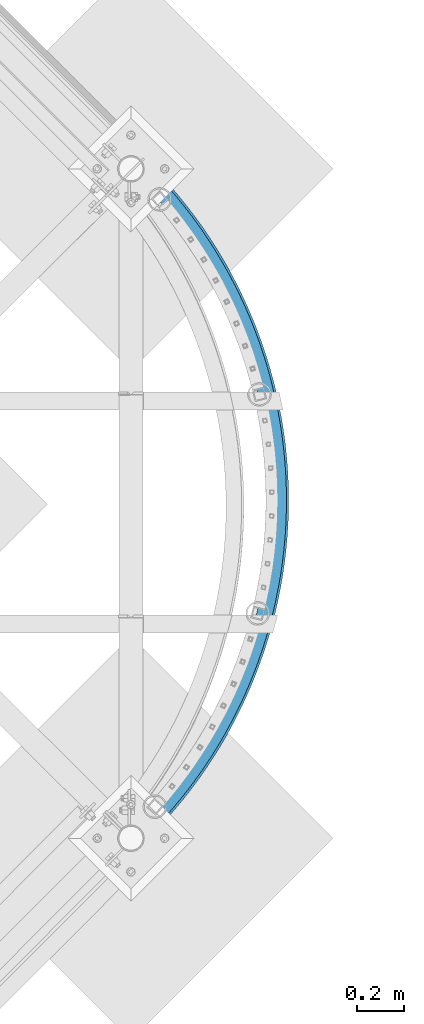
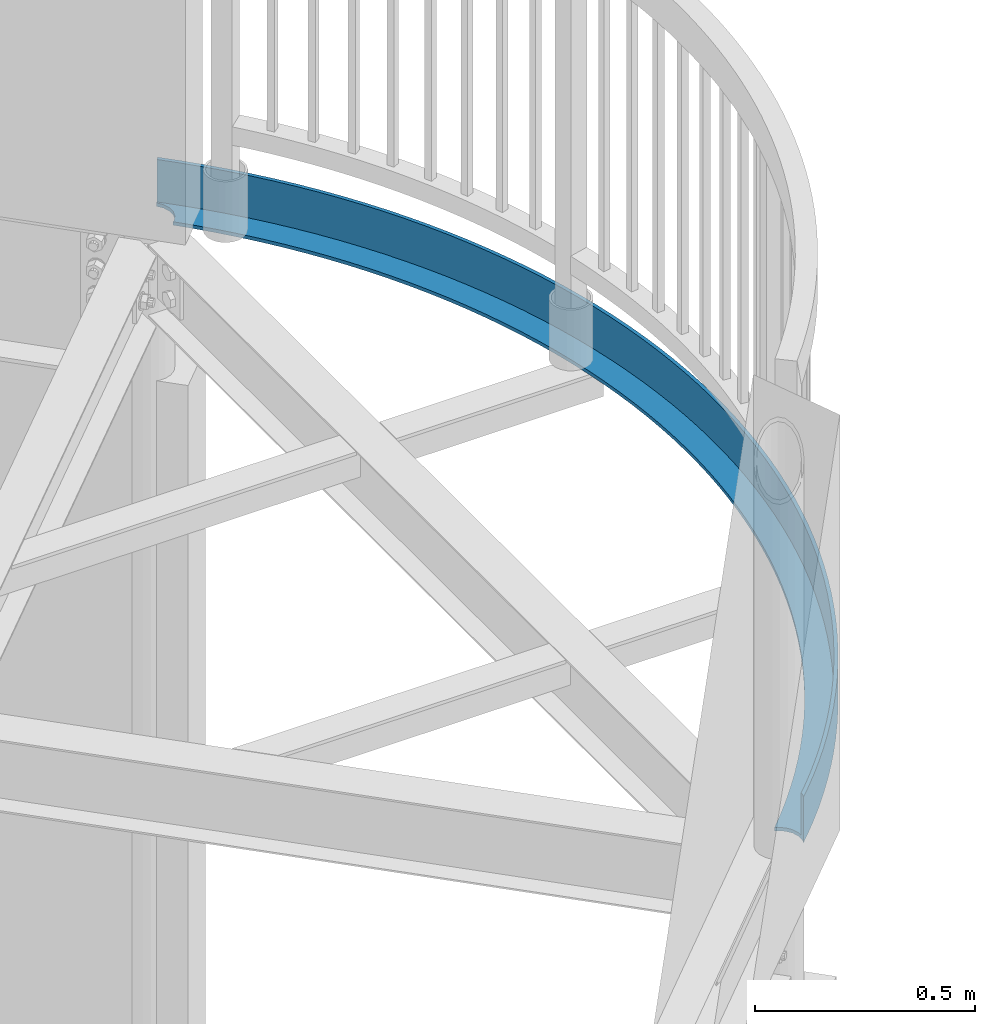
# One storey, part 372 of 975: 1 beam.
"""IFC2X3 building model written with IfcOpenShell, lengths in millimetres."""

from ifc_helpers import new_model, si_unit, frame, origin_with_axes, place, context, subcontext, project, spatial, faceted_brep, material, type_object, element, save


model = new_model("IFC2X3")

# Units and contexts
model_context = context("Model", 3, precision=1e-05, world=origin_with_axes())
body_context = subcontext(model_context, "Body", "Model", "MODEL_VIEW")
ifc_project = project(units=[si_unit("LENGTHUNIT", "METRE", prefix="MILLI"), si_unit("AREAUNIT", "SQUARE_METRE"), si_unit("VOLUMEUNIT", "CUBIC_METRE"), si_unit("MASSUNIT", "GRAM", prefix="KILO"), si_unit("TIMEUNIT", "SECOND"), si_unit("PLANEANGLEUNIT", "RADIAN"), si_unit("SOLIDANGLEUNIT", "STERADIAN"), si_unit("THERMODYNAMICTEMPERATUREUNIT", "DEGREE_CELSIUS"), si_unit("LUMINOUSINTENSITYUNIT", "LUMEN")], contexts=[model_context])

# Site, building, storey
site_placement = place(None, origin_with_axes())
site = spatial("IfcSite", under=ifc_project, at=site_placement, CompositionType="ELEMENT")
building_placement = place(site_placement, origin_with_axes())
building = spatial("IfcBuilding", under=site, at=building_placement, Name="Undefined", CompositionType="ELEMENT")
storey_placement = place(building_placement, origin_with_axes())
storey = spatial("IfcBuildingStorey", under=building, at=storey_placement, Name="Undefined", CompositionType="ELEMENT", Elevation=0.0)

# Beam
ifc_material = material(Name="STEEL/A36")
beam_type = type_object("IfcBeamType", Name="L5X3X3/8", PredefinedType="NOTDEFINED")
beam_placement = place(storey_placement, frame((35561.2099858616, 13119.3966204325, 4000.5), z_axis=(0.0, 0.0, 1.0), x_axis=(-0.00469841200188729, -0.999988962401416, 0.0)))
element("IfcBeam", 1, at=beam_placement, inside=storey, type_object=beam_type, material=ifc_material, Name="ANGLE", ObjectType="L5X3X3/8", context=body_context, shape_type="Brep", body=[
    faceted_brep([(2825.13390224894, 8.48867532257282, -53.9749999999999), (2825.13390224894, 8.48867532257282, -63.5), (2827.4700929227, 15.7953649505871, -63.5), (2827.4700929227, 15.7953649505871, -53.9750000000004), (2837.91188190403, 30.3101804705875, -63.5), (2837.91188190403, 30.3101804705875, -53.9750000000004), (2852.32793802244, 40.8879001067689, -63.5), (2852.32793802244, 40.8879001067689, -53.9749999999999), (2869.30711726249, 46.4931029618456, -63.5), (2869.30711726249, 46.4931029618456, -53.9749999999999), (2881.17687559119, 46.5488725923351, 63.5), (2881.17687559119, 46.5488725923351, -53.9749999999999), (2887.18737925926, 46.5771127266125, -63.5), (2887.18737925926, 46.5771127266125, 63.5), (2897.80763996452, 43.1814636329655, 63.5), (2897.80763996452, 43.1814636329655, -63.5), (2828.72669331991, 97.9177942949682, 63.5), (2828.72669331991, 97.9177942949682, -53.9749999999999), (2868.63149026365, 59.3560200991269, -53.9749999999999), (2868.63149026365, 59.3560200991269, 63.5), (2787.77896454822, 135.370254250112, 63.5), (2787.77896454822, 135.370254250112, -53.9749999999999), (2745.81913086308, 171.685204413458, 63.5), (2745.81913086308, 171.685204413458, -53.9749999999999), (2702.87878112772, 206.835305591929, 63.5), (2702.87878112772, 206.835305591929, -53.9749999999999), (2658.99024237294, 240.794095532416, 63.5), (2658.99024237294, 240.794095532416, -53.9749999999999), (2614.18655546014, 273.536008843497, 63.5), (2614.18655546014, 273.536008843497, -53.9749999999999), (2568.50145020696, 305.036396242016, 63.5), (2568.50145020696, 305.036396242016, -53.9749999999999), (2521.9693199943, 335.271543109913, 63.5), (2521.9693199943, 335.271543109913, -53.9749999999999), (2474.62519587376, 364.218687347442, 63.5), (2474.62519587376, 364.218687347442, -53.9749999999999), (2426.50472019493, 391.856036509293, 63.5), (2426.50472019493, 391.856036509293, -53.9749999999999), (2377.64411977268, 418.162784210719, 63.5), (2377.64411977268, 418.162784210719, -53.9749999999999), (2328.08017861421, 443.119125791352, 63.5), (2328.08017861421, 443.119125791352, -53.9749999999999), (2277.8502102268, 466.706273224831, 63.5), (2277.8502102268, 466.706273224831, -53.9749999999999), (2226.99202952682, 488.9064692631, 63.5), (2226.99202952682, 488.9064692631, -53.9749999999999), (2175.54392437137, 509.70300080473, 63.5), (2175.54392437137, 509.70300080473, -53.9749999999999), (2123.54462673375, 529.080211477107, 63.5), (2123.54462673375, 529.080211477107, -53.9749999999999), (2071.03328354467, 547.023513423112, 63.5), (2071.03328354467, 547.023513423112, -53.9749999999999), (2018.04942722104, 563.519398283424, 63.5), (2018.04942722104, 563.519398283424, -53.9749999999999), (1964.63294590458, 578.555447366016, 63.5), (1964.63294590458, 578.555447366016, -53.9749999999999), (1910.82405343254, 592.120340995476, 63.5), (1910.82405343254, 592.120340995476, -53.9749999999999), (1856.66325906335, 604.203867034805, 63.5), (1856.66325906335, 604.203867034805, -53.9749999999999), (1802.19133697975, 614.796928573509, 63.5), (1802.19133697975, 614.796928573509, -53.9749999999999), (1747.44929559255, 623.891550776047, 63.5), (1747.44929559255, 623.891550776047, -53.9749999999999), (1692.47834666806, 631.480886885627, 63.5), (1692.47834666806, 631.480886885627, -53.9749999999999), (1637.31987430233, 637.55922337863, 63.5), (1637.31987430233, 637.55922337863, -53.9749999999999), (1582.01540376579, 642.121984265985, 63.5), (1582.01540376579, 642.121984265985, -53.9749999999999), (1526.6065702415, 645.165734538132, 63.5), (1526.6065702415, 645.165734538132, -53.9749999999999), (1471.13508748072, 646.68818275103, 63.5), (1471.13508748072, 646.68818275103, -53.9749999999999), (1415.64271639927, 646.688182751226, 63.5), (1415.64271639927, 646.688182751226, -53.9749999999999), (1360.17123363849, 645.165734538714, 63.5), (1360.17123363849, 645.165734538714, -53.9749999999999), (1304.7624001142, 642.121984266945, 63.5), (1304.7624001142, 642.121984266945, -53.9749999999999), (1249.45792957766, 637.559223379991, 63.5), (1249.45792957766, 637.559223379991, -53.9749999999999), (1194.29945721193, 631.480886887373, 63.5), (1194.29945721193, 631.480886887373, -53.9749999999999), (1139.32850828744, 623.891550778178, 63.5), (1139.32850828744, 623.891550778178, -53.9749999999999), (1084.58646690025, 614.796928576012, 63.5), (1084.58646690025, 614.796928576012, -53.9749999999999), (1030.11454481665, 604.203867037693, 63.5), (1030.11454481665, 604.203867037693, -53.9749999999999), (975.953750447461, 592.120340998743, 63.5), (975.953750447461, 592.120340998743, -53.9749999999999), (922.144857975429, 578.555447369661, 63.5), (922.144857975429, 578.555447369661, -53.9749999999999), (868.728376658968, 563.519398287433, 63.5), (868.728376658968, 563.519398287433, -53.9749999999999), (815.744520335351, 547.023513427499, 63.5), (815.744520335351, 547.023513427499, -53.9749999999999), (763.233177146274, 529.080211481858, 63.5), (763.233177146274, 529.080211481858, -53.9749999999999), (711.233879508653, 509.703000809852, 63.5), (711.233879508653, 509.703000809852, -53.9749999999999), (659.785774353209, 488.906469268579, 63.5), (659.785774353209, 488.906469268579, -53.9749999999999), (608.927593653245, 466.706273230659, 63.5), (608.927593653245, 466.706273230659, -53.9749999999999), (558.697625265839, 443.119125797537, 63.5), (558.697625265839, 443.119125797537, -53.9749999999999), (509.133684107373, 418.162784217253, 63.5), (509.133684107373, 418.162784217253, -53.9749999999999), (460.273083685131, 391.856036516161, 63.5), (460.273083685131, 391.856036516161, -53.9749999999999), (412.152608006316, 364.218687354653, 63.5), (412.152608006316, 364.218687354653, -53.9749999999999), (364.80848388577, 335.271543117451, 63.5), (364.80848388577, 335.271543117451, -53.9749999999999), (318.276353673127, 305.036396249874, 63.5), (318.276353673127, 305.036396249874, -53.9749999999999), (272.591248419958, 273.536008851675, 63.5), (272.591248419958, 273.536008851675, -53.9749999999999), (227.787561507164, 240.794095540907, 63.5), (227.787561507164, 240.794095540907, -53.9749999999999), (183.899022752392, 206.83530560074, 63.5), (183.899022752392, 206.83530560074, -53.9749999999999), (140.958673017045, 171.685204422567, 63.5), (140.958673017045, 171.685204422567, -53.9749999999999), (98.998839331909, 135.370254259513, 63.5), (98.998839331909, 135.370254259513, -53.9749999999999), (58.0511105602363, 97.9177943046452, 63.5), (58.0511105602363, 97.9177943046452, -53.9749999999999), (18.1463136165039, 59.356020109095, 63.5), (18.1463136165039, 59.356020109095, -53.9749999999999), (-20.6855097411844, 19.7139623554103, 63.5), (-20.6855097411844, 19.7139623554103, -53.9749999999999), (2783.05621668102, 49.3404004933182, -53.9749999999999), (2783.05621668102, 49.3404004933182, -63.5), (2821.64547086838, 12.0498935786673, -63.5), (2821.64547086838, 12.0498935786673, -53.9749999999999), (2743.45841303368, 85.5581639664306, -53.9749999999999), (2743.45841303368, 85.5581639664306, -63.5), (2702.88187056892, 120.675917970548, -53.9749999999999), (2702.88187056892, 120.675917970548, -63.5), (2661.3571367589, 154.667224604666, -53.9749999999999), (2661.3571367589, 154.667224604666, -63.5), (2618.91547290813, 187.506493997658, -53.9749999999999), (2618.91547290813, 187.506493997658, -63.5), (2575.58883061882, 219.169003573203, -53.9749999999999), (2575.58883061882, 219.169003573203, -63.5), (2531.40982773663, 249.630916661888, -53.9749999999999), (2531.40982773663, 249.630916661888, -63.5), (2486.41172379472, 278.869300446233, -53.9749999999999), (2486.41172379472, 278.869300446233, -63.5), (2440.62839497485, 306.862143225379, -53.9749999999999), (2440.62839497485, 306.862143225379, -63.5), (2394.09430860412, 333.58837098629, -53.9749999999999), (2394.09430860412, 333.58837098629, -63.5), (2346.84449720677, 359.027863268995, -53.9749999999999), (2346.84449720677, 359.027863268995, -63.5), (2298.91453213045, 383.161468314, -53.9749999999999), (2298.91453213045, 383.161468314, -63.5), (2250.3404967668, 405.971017480435, -53.9749999999999), (2250.3404967668, 405.971017480435, -63.5), (2201.15895938661, 427.439338924043, -53.9749999999999), (2201.15895938661, 427.439338924043, -63.5), (2151.40694560991, 447.550270524742, -53.9749999999999), (2151.40694560991, 447.550270524742, -63.5), (2101.12191053177, 466.288672054063, -53.9749999999999), (2101.12191053177, 466.288672054063, -63.5), (2050.34171052474, 483.640436573289, -53.9749999999999), (2050.34171052474, 483.640436573289, -63.5), (1999.10457473926, 499.592501053579, -53.9749999999999), (1999.10457473926, 499.592501053579, -63.5), (1947.44907632334, 514.132856210374, -53.9749999999999), (1947.44907632334, 514.132856210374, -63.5), (1895.41410338335, 527.250555544357, -53.9749999999999), (1895.41410338335, 527.250555544357, -63.5), (1843.03882970764, 538.935723582392, -53.9749999999999), (1843.03882970764, 538.935723582392, -63.5), (1790.36268527515, 549.179563312122, -53.9749999999999), (1790.36268527515, 549.179563312122, -63.5), (1737.42532657105, 557.974362804693, -53.9749999999999), (1737.42532657105, 557.974362804693, -63.5), (1684.26660673198, 565.313501020544, -53.9749999999999), (1684.26660673198, 565.313501020544, -63.5), (1630.92654554314, 571.191452794003, -53.9749999999999), (1630.92654554314, 571.191452794003, -63.5), (1577.44529931, 575.603792992762, -53.9749999999999), (1577.44529931, 575.603792992762, -63.5), (1523.86313062717, 578.547199849352, -53.9749999999999), (1523.86313062717, 578.547199849352, -63.5), (1470.2203780673, 580.019457461822, -53.9749999999999), (1470.2203780673, 580.019457461822, -63.5), (1416.55742581271, 580.019457462011, -53.9749999999999), (1416.55742581271, 580.019457462011, -63.5), (1362.91467325283, 578.547199849912, -53.9749999999999), (1362.91467325283, 578.547199849912, -63.5), (1309.33250457, 575.603792993701, -53.9749999999999), (1309.33250457, 575.603792993701, -63.5), (1255.85125833687, 571.191452795312, -53.9749999999999), (1255.85125833687, 571.191452795312, -63.5), (1202.51119714803, 565.313501022232, -53.9749999999999), (1202.51119714803, 565.313501022232, -63.5), (1149.35247730896, 557.974362806744, -53.9749999999999), (1149.35247730896, 557.974362806744, -63.5), (1096.41511860487, 549.179563314545, -53.9749999999999), (1096.41511860487, 549.179563314545, -63.5), (1043.73897417237, 538.935723585186, -53.9749999999999), (1043.73897417237, 538.935723585186, -63.5), (991.363700496677, 527.250555547515, -53.9749999999999), (991.363700496677, 527.250555547515, -63.5), (939.328727556689, 514.132856213902, -53.9749999999999), (939.328727556689, 514.132856213902, -63.5), (887.673229140772, 499.592501057457, -53.9749999999999), (887.673229140772, 499.592501057457, -63.5), (836.436093355293, 483.640436577523, -53.9749999999999), (836.436093355293, 483.640436577523, -63.5), (785.655893348276, 466.288672058668, -53.9749999999999), (785.655893348276, 466.288672058668, -63.5), (735.370858270137, 447.550270529689, -53.9749999999999), (735.370858270137, 447.550270529689, -63.5), (685.618844493443, 427.439338929333, -53.9749999999999), (685.618844493443, 427.439338929333, -63.5), (636.437307113256, 405.971017486081, -53.9749999999999), (636.437307113256, 405.971017486081, -63.5), (587.863271749609, 383.16146831998, -53.9749999999999), (587.863271749609, 383.16146831998, -63.5), (539.933306673296, 359.027863275311, -53.9749999999999), (539.933306673296, 359.027863275311, -63.5), (492.683495275958, 333.58837099294, -53.9749999999999), (492.683495275958, 333.58837099294, -63.5), (446.149408905236, 306.862143232356, -53.9749999999999), (446.149408905236, 306.862143232356, -63.5), (400.36608008537, 278.869300453523, -53.9749999999999), (400.36608008537, 278.869300453523, -63.5), (355.367976143472, 249.630916669492, -53.9749999999999), (355.367976143472, 249.630916669492, -63.5), (311.188973261287, 219.169003581119, -53.9749999999999), (311.188973261287, 219.169003581119, -63.5), (267.862330971991, 187.506494005873, -53.9749999999999), (267.862330971991, 187.506494005873, -63.5), (225.420667121225, 154.667224613178, -53.9749999999999), (225.420667121225, 154.667224613178, -63.5), (183.895933311216, 120.675917979344, -53.9749999999999), (183.895933311216, 120.675917979344, -63.5), (143.319390846471, 85.558163975511, -53.9749999999999), (143.319390846471, 85.558163975511, -63.5), (103.721587199139, 49.340400502675, -53.9749999999999), (103.721587199139, 49.340400502675, -63.5), (66.0401089182997, 12.9271176868497, -53.9749999999999), (66.0401089182997, 12.9271176868497, -63.5), (62.8523170566423, 17.2716633876989, -53.9750000000004), (62.8523170566423, 17.2716633876989, -63.5), (48.3375015365273, 27.7134523691129, -53.9750000000004), (48.3375015365273, 27.7134523691129, -63.5), (31.3064014063893, 33.1588591557738, -53.9750000000004), (31.3064014063893, 33.1588591557738, -63.5), (13.4261394096193, 33.0748493910069, -53.9750000000004), (13.4261394096193, 33.0748493910069, -63.5), (-3.55303983042359, 27.4696465359302, -53.9750000000004), (-3.55303983042359, 27.4696465359302, -63.5), (-17.8526282800794, 17.0141343511568, -53.9749999999999), (-17.8526282800794, 17.0141343511568, -63.5), (-27.5806796549132, 26.2852831405398, 63.5), (-27.5806796549132, 26.2852831405398, -63.5), (11.4340251314625, 66.1140381834994, 63.5), (11.4340251314625, 66.1140381834994, -63.5), (51.5267567546798, 104.857421990644, 63.5), (51.5267567546798, 104.857421990644, -63.5), (92.667331972687, 142.486267157226, 63.5), (92.667331972687, 142.486267157226, -63.5), (134.824778689306, 178.972245343029, 63.5), (134.824778689306, 178.972245343029, -63.5), (177.967359271133, 214.287888598948, 63.5), (177.967359271133, 214.287888598948, -63.5), (222.06259444076, 248.406610045902, 63.5), (222.06259444076, 248.406610045902, -63.5), (267.07728772834, 281.302723890331, 63.5), (267.07728772834, 281.302723890331, -63.5), (312.97755046308, 312.951464761361, 63.5), (312.97755046308, 312.951464761361, -63.5), (359.728827285828, 343.329006355154, 63.5), (359.728827285828, 343.329006355154, -63.5), (407.29592216361, 372.412479372113, 63.5), (407.29592216361, 372.412479372113, -63.5), (455.64302488644, 400.179988733762, 63.5), (455.64302488644, 400.179988733762, -63.5), (504.733738026529, 426.610630066098, 63.5), (504.733738026529, 426.610630066098, -63.5), (554.531104339585, 451.684505437188, 63.5), (554.531104339585, 451.684505437188, -63.5), (604.997634587529, 475.38273833703, 63.5), (604.997634587529, 475.38273833703, -63.5), (656.095335761749, 497.68748788847, 63.5), (656.095335761749, 497.68748788847, -63.5), (707.785739685585, 518.58196227844, 63.5), (707.785739685585, 518.58196227844, -63.5), (760.029931974559, 538.050431399453, 63.5), (760.029931974559, 538.050431399453, -63.5), (812.788581332501, 556.078238691778, 63.5), (812.788581332501, 556.078238691778, -63.5), (866.021969161568, 572.651812177435, 63.5), (866.021969161568, 572.651812177435, -63.5), (919.69001946382, 587.758674677621, 63.5), (919.69001946382, 587.758674677621, -63.5), (973.752329011859, 601.387453206058, 63.5), (973.752329011859, 601.387453206058, -63.5), (1028.16819776583, 613.527887530909, 63.5), (1028.16819776583, 613.527887530909, -63.5), (1082.89665951388, 624.170837899081, 63.5), (1082.89665951388, 624.170837899081, -63.5), (1137.89651271294, 633.308291916954, 63.5), (1137.89651271294, 633.308291916954, -63.5), (1193.12635150678, 640.933370582388, 63.5), (1193.12635150678, 640.933370582388, -63.5), (1248.54459689777, 647.040333463512, 63.5), (1248.54459689777, 647.040333463512, -63.5), (1304.10952804908, 651.624583020282, 63.5), (1304.10952804908, 651.624583020282, -63.5), (1359.77931369358, 654.682668065689, 63.5), (1359.77931369358, 654.682668065689, -63.5), (1415.51204362592, 656.212286363967, 63.5), (1415.51204362592, 656.212286363967, -63.5), (1471.26576025406, 656.212286363778, 63.5), (1471.26576025406, 656.212286363778, -63.5), (1526.9984901864, 654.682668065099, 63.5), (1526.9984901864, 654.682668065099, -63.5), (1582.6682758309, 651.6245830193, 63.5), (1582.6682758309, 651.6245830193, -63.5), (1638.23320698222, 647.040333462151, 63.5), (1638.23320698222, 647.040333462151, -63.5), (1693.65145237321, 640.933370580635, 63.5), (1693.65145237321, 640.933370580635, -63.5), (1748.88129116705, 633.308291914815, 63.5), (1748.88129116705, 633.308291914815, -63.5), (1803.88114436612, 624.170837896563, 63.5), (1803.88114436612, 624.170837896563, -63.5), (1858.60960611416, 613.527887528006, 63.5), (1858.60960611416, 613.527887528006, -63.5), (1913.02547486814, 601.387453202777, 63.5), (1913.02547486814, 601.387453202777, -63.5), (1967.08778441618, 587.758674673962, 63.5), (1967.08778441618, 587.758674673962, -63.5), (2020.75583471844, 572.651812173397, 63.5), (2020.75583471844, 572.651812173397, -63.5), (2073.98922254751, 556.078238687376, 63.5), (2073.98922254751, 556.078238687376, -63.5), (2126.74787190546, 538.050431394673, 63.5), (2126.74787190546, 538.050431394673, -63.5), (2178.99206419444, 518.581962273303, 63.5), (2178.99206419444, 518.581962273303, -63.5), (2230.68246811828, 497.687487882969, 63.5), (2230.68246811828, 497.687487882969, -63.5), (2281.78016929251, 475.382738331165, 63.5), (2281.78016929251, 475.382738331165, -63.5), (2332.24669954046, 451.684505430974, 63.5), (2332.24669954046, 451.684505430974, -63.5), (2382.04406585352, 426.610630059542, 63.5), (2382.04406585352, 426.610630059542, -63.5), (2431.13477899362, 400.179988726857, 63.5), (2431.13477899362, 400.179988726857, -63.5), (2479.48188171646, 372.412479364881, 63.5), (2479.48188171646, 372.412479364881, -63.5), (2527.04897659425, 343.329006347587, 63.5), (2527.04897659425, 343.329006347587, -63.5), (2573.800253417, 312.951464753452, 63.5), (2573.800253417, 312.951464753452, -63.5), (2619.70051615175, 281.302723882109, 63.5), (2619.70051615175, 281.302723882109, -63.5), (2664.71520943934, 248.406610037375, 63.5), (2664.71520943934, 248.406610037375, -63.5), (2708.81044460898, 214.287888590108, 63.5), (2708.81044460898, 214.287888590108, -63.5), (2751.95302519082, 178.972245333884, 63.5), (2751.95302519082, 178.972245333884, -63.5), (2794.11047190745, 142.486267147789, 63.5), (2794.11047190745, 142.486267147789, -63.5), (2835.25104712546, 104.857421980916, 63.5), (2835.25104712546, 104.857421980916, -63.5), (2875.34377874869, 66.1140381734876, 63.5), (2875.34377874869, 66.1140381734876, -63.5)], [[[0, 1, 2, 3]], [[3, 2, 4, 5]], [[5, 4, 6, 7]], [[7, 6, 8, 9]], [[10, 11, 9, 8, 12, 13]], [[14, 13, 12, 15]], [[16, 17, 18, 19]], [[20, 21, 17, 16]], [[22, 23, 21, 20]], [[24, 25, 23, 22]], [[26, 27, 25, 24]], [[28, 29, 27, 26]], [[30, 31, 29, 28]], [[32, 33, 31, 30]], [[34, 35, 33, 32]], [[36, 37, 35, 34]], [[38, 39, 37, 36]], [[40, 41, 39, 38]], [[42, 43, 41, 40]], [[44, 45, 43, 42]], [[46, 47, 45, 44]], [[48, 49, 47, 46]], [[50, 51, 49, 48]], [[52, 53, 51, 50]], [[54, 55, 53, 52]], [[56, 57, 55, 54]], [[58, 59, 57, 56]], [[60, 61, 59, 58]], [[62, 63, 61, 60]], [[64, 65, 63, 62]], [[66, 67, 65, 64]], [[68, 69, 67, 66]], [[70, 71, 69, 68]], [[72, 73, 71, 70]], [[74, 75, 73, 72]], [[76, 77, 75, 74]], [[78, 79, 77, 76]], [[80, 81, 79, 78]], [[82, 83, 81, 80]], [[84, 85, 83, 82]], [[86, 87, 85, 84]], [[88, 89, 87, 86]], [[90, 91, 89, 88]], [[92, 93, 91, 90]], [[94, 95, 93, 92]], [[96, 97, 95, 94]], [[98, 99, 97, 96]], [[100, 101, 99, 98]], [[102, 103, 101, 100]], [[104, 105, 103, 102]], [[106, 107, 105, 104]], [[108, 109, 107, 106]], [[110, 111, 109, 108]], [[112, 113, 111, 110]], [[114, 115, 113, 112]], [[116, 117, 115, 114]], [[118, 119, 117, 116]], [[120, 121, 119, 118]], [[122, 123, 121, 120]], [[124, 125, 123, 122]], [[126, 127, 125, 124]], [[128, 129, 127, 126]], [[130, 131, 129, 128]], [[132, 133, 131, 130]], [[134, 135, 136, 137]], [[138, 139, 135, 134]], [[140, 141, 139, 138]], [[142, 143, 141, 140]], [[144, 145, 143, 142]], [[146, 147, 145, 144]], [[148, 149, 147, 146]], [[150, 151, 149, 148]], [[152, 153, 151, 150]], [[154, 155, 153, 152]], [[156, 157, 155, 154]], [[158, 159, 157, 156]], [[160, 161, 159, 158]], [[162, 163, 161, 160]], [[164, 165, 163, 162]], [[166, 167, 165, 164]], [[168, 169, 167, 166]], [[170, 171, 169, 168]], [[172, 173, 171, 170]], [[174, 175, 173, 172]], [[176, 177, 175, 174]], [[178, 179, 177, 176]], [[180, 181, 179, 178]], [[182, 183, 181, 180]], [[184, 185, 183, 182]], [[186, 187, 185, 184]], [[188, 189, 187, 186]], [[190, 191, 189, 188]], [[192, 193, 191, 190]], [[194, 195, 193, 192]], [[196, 197, 195, 194]], [[198, 199, 197, 196]], [[200, 201, 199, 198]], [[202, 203, 201, 200]], [[204, 205, 203, 202]], [[206, 207, 205, 204]], [[208, 209, 207, 206]], [[210, 211, 209, 208]], [[212, 213, 211, 210]], [[214, 215, 213, 212]], [[216, 217, 215, 214]], [[218, 219, 217, 216]], [[220, 221, 219, 218]], [[222, 223, 221, 220]], [[224, 225, 223, 222]], [[226, 227, 225, 224]], [[228, 229, 227, 226]], [[230, 231, 229, 228]], [[232, 233, 231, 230]], [[234, 235, 233, 232]], [[236, 237, 235, 234]], [[238, 239, 237, 236]], [[240, 241, 239, 238]], [[242, 243, 241, 240]], [[244, 245, 243, 242]], [[246, 247, 245, 244]], [[247, 246, 248, 249]], [[248, 250, 251, 249]], [[252, 253, 251, 250]], [[254, 255, 253, 252]], [[256, 257, 255, 254]], [[258, 259, 257, 256]], [[260, 261, 259, 258]], [[133, 132, 262, 263, 261, 260]], [[263, 262, 264, 265]], [[265, 264, 266, 267]], [[267, 266, 268, 269]], [[269, 268, 270, 271]], [[271, 270, 272, 273]], [[273, 272, 274, 275]], [[275, 274, 276, 277]], [[277, 276, 278, 279]], [[279, 278, 280, 281]], [[281, 280, 282, 283]], [[283, 282, 284, 285]], [[285, 284, 286, 287]], [[287, 286, 288, 289]], [[289, 288, 290, 291]], [[291, 290, 292, 293]], [[293, 292, 294, 295]], [[295, 294, 296, 297]], [[297, 296, 298, 299]], [[299, 298, 300, 301]], [[301, 300, 302, 303]], [[303, 302, 304, 305]], [[305, 304, 306, 307]], [[307, 306, 308, 309]], [[309, 308, 310, 311]], [[311, 310, 312, 313]], [[313, 312, 314, 315]], [[315, 314, 316, 317]], [[317, 316, 318, 319]], [[319, 318, 320, 321]], [[321, 320, 322, 323]], [[323, 322, 324, 325]], [[325, 324, 326, 327]], [[327, 326, 328, 329]], [[329, 328, 330, 331]], [[331, 330, 332, 333]], [[333, 332, 334, 335]], [[335, 334, 336, 337]], [[337, 336, 338, 339]], [[339, 338, 340, 341]], [[341, 340, 342, 343]], [[343, 342, 344, 345]], [[345, 344, 346, 347]], [[347, 346, 348, 349]], [[349, 348, 350, 351]], [[351, 350, 352, 353]], [[353, 352, 354, 355]], [[355, 354, 356, 357]], [[357, 356, 358, 359]], [[359, 358, 360, 361]], [[361, 360, 362, 363]], [[363, 362, 364, 365]], [[365, 364, 366, 367]], [[367, 366, 368, 369]], [[369, 368, 370, 371]], [[371, 370, 372, 373]], [[373, 372, 374, 375]], [[375, 374, 376, 377]], [[377, 376, 378, 379]], [[379, 378, 14, 15]], [[8, 6, 4, 2, 1, 136, 135, 139, 141, 143, 145, 147, 149, 151, 153, 155, 157, 159, 161, 163, 165, 167, 169, 171, 173, 175, 177, 179, 181, 183, 185, 187, 189, 191, 193, 195, 197, 199, 201, 203, 205, 207, 209, 211, 213, 215, 217, 219, 221, 223, 225, 227, 229, 231, 233, 235, 237, 239, 241, 243, 245, 247, 249, 251, 253, 255, 257, 259, 261, 263, 265, 267, 269, 271, 273, 275, 277, 279, 281, 283, 285, 287, 289, 291, 293, 295, 297, 299, 301, 303, 305, 307, 309, 311, 313, 315, 317, 319, 321, 323, 325, 327, 329, 331, 333, 335, 337, 339, 341, 343, 345, 347, 349, 351, 353, 355, 357, 359, 361, 363, 365, 367, 369, 371, 373, 375, 377, 379, 15, 12]], [[137, 136, 1, 0]], [[18, 17, 21, 23, 25, 27, 29, 31, 33, 35, 37, 39, 41, 43, 45, 47, 49, 51, 53, 55, 57, 59, 61, 63, 65, 67, 69, 71, 73, 75, 77, 79, 81, 83, 85, 87, 89, 91, 93, 95, 97, 99, 101, 103, 105, 107, 109, 111, 113, 115, 117, 119, 121, 123, 125, 127, 129, 131, 133, 260, 258, 256, 254, 252, 250, 248, 246, 244, 242, 240, 238, 236, 234, 232, 230, 228, 226, 224, 222, 220, 218, 216, 214, 212, 210, 208, 206, 204, 202, 200, 198, 196, 194, 192, 190, 188, 186, 184, 182, 180, 178, 176, 174, 172, 170, 168, 166, 164, 162, 160, 158, 156, 154, 152, 150, 148, 146, 144, 142, 140, 138, 134, 137, 0, 3, 5, 7, 9, 11]], [[19, 18, 11, 10]], [[378, 376, 374, 372, 370, 368, 366, 364, 362, 360, 358, 356, 354, 352, 350, 348, 346, 344, 342, 340, 338, 336, 334, 332, 330, 328, 326, 324, 322, 320, 318, 316, 314, 312, 310, 308, 306, 304, 302, 300, 298, 296, 294, 292, 290, 288, 286, 284, 282, 280, 278, 276, 274, 272, 270, 268, 266, 264, 262, 132, 130, 128, 126, 124, 122, 120, 118, 116, 114, 112, 110, 108, 106, 104, 102, 100, 98, 96, 94, 92, 90, 88, 86, 84, 82, 80, 78, 76, 74, 72, 70, 68, 66, 64, 62, 60, 58, 56, 54, 52, 50, 48, 46, 44, 42, 40, 38, 36, 34, 32, 30, 28, 26, 24, 22, 20, 16, 19, 10, 13, 14]]]),
])

save(model, "model.ifc")
